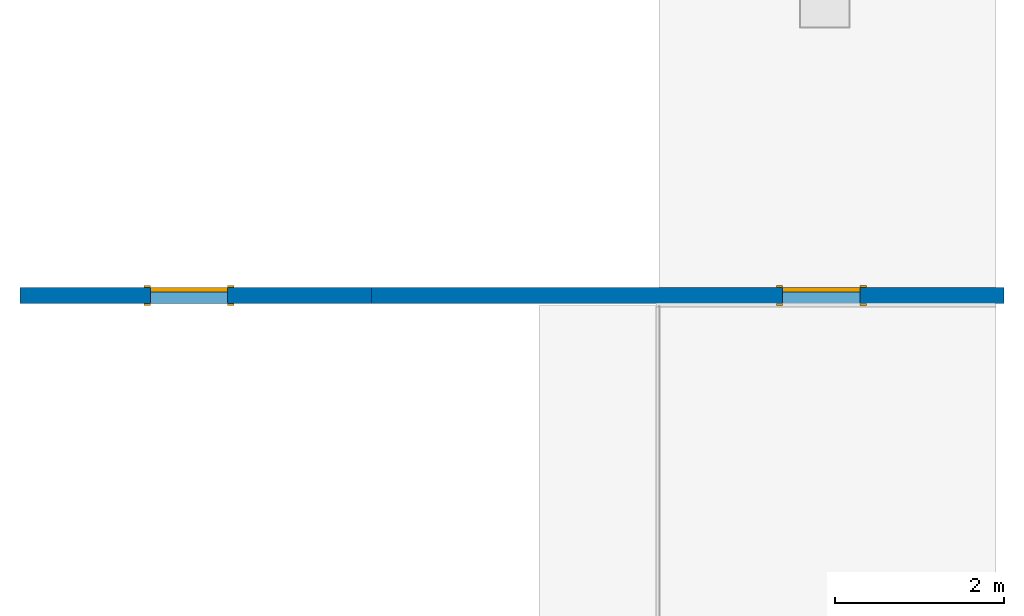
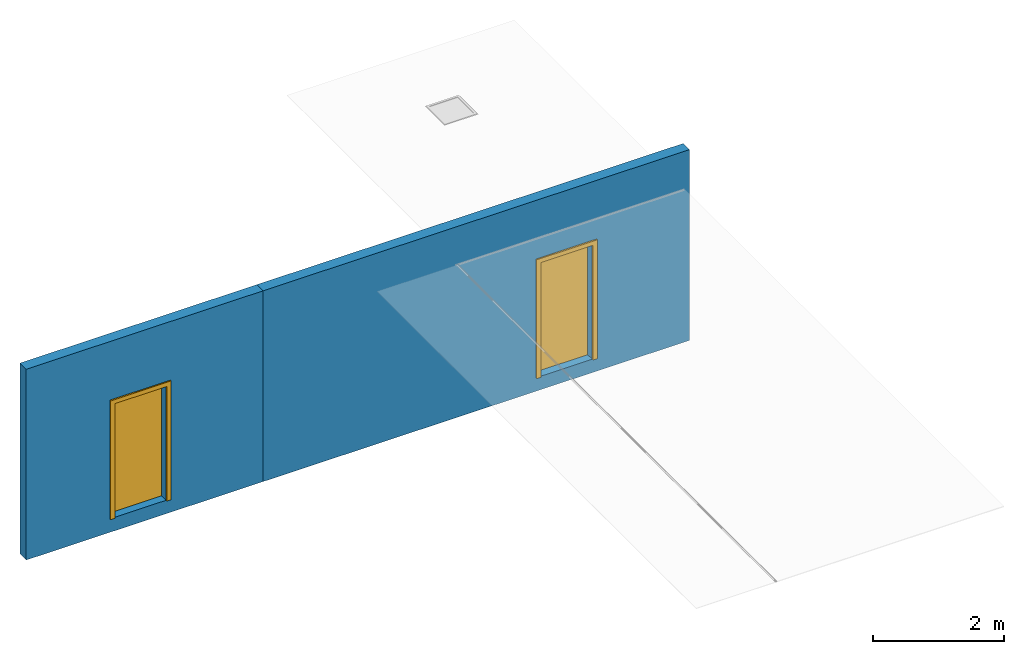
# One storey, part 1 of 4: 2 doors, 2 walls, 2 openings.
"""IFC2X3 building model written with IfcOpenShell, lengths in millimetres."""

from ifc_helpers import new_model, entity, si_unit, converted_unit, derived_unit, direction, frame, frame_2d, origin, place, context, subcontext, project, spatial, polyline, rectangle, outline, extrude, source, transform, mapped, material, material_list, layer, layer_set, layer_usage, type_object, type_shapes, element, fill, save


model = new_model("IFC2X3")

# Units and contexts
model_context = context("Model", 3, precision=0.01, world=origin(), true_north=direction((6.12303176911189e-17, 1.0)))
body_context = subcontext(model_context, "Body", "Model", "MODEL_VIEW")
ifc_project = project(units=[si_unit("LENGTHUNIT", "METRE", prefix="MILLI"), si_unit("AREAUNIT", "SQUARE_METRE"), si_unit("VOLUMEUNIT", "CUBIC_METRE"), converted_unit("PLANEANGLEUNIT", "DEGREE", entity("IfcRatioMeasure", 0.0174532925199433), si_unit("PLANEANGLEUNIT", "RADIAN"), dimensions=[0, 0, 0, 0, 0, 0, 0]), si_unit("MASSUNIT", "GRAM", prefix="KILO"), derived_unit("MASSDENSITYUNIT", [(si_unit("MASSUNIT", "GRAM", prefix="KILO"), 1), (si_unit("LENGTHUNIT", "METRE"), -3)]), si_unit("TIMEUNIT", "SECOND"), si_unit("FREQUENCYUNIT", "HERTZ"), si_unit("THERMODYNAMICTEMPERATUREUNIT", "DEGREE_CELSIUS"), derived_unit("THERMALTRANSMITTANCEUNIT", [(si_unit("MASSUNIT", "GRAM", prefix="KILO"), 1), (si_unit("THERMODYNAMICTEMPERATUREUNIT", "KELVIN"), -1), (si_unit("TIMEUNIT", "SECOND"), -3)]), derived_unit("VOLUMETRICFLOWRATEUNIT", [(si_unit("LENGTHUNIT", "METRE"), 3), (si_unit("TIMEUNIT", "SECOND"), -1)]), si_unit("ELECTRICCURRENTUNIT", "AMPERE"), si_unit("ELECTRICVOLTAGEUNIT", "VOLT"), si_unit("POWERUNIT", "WATT"), si_unit("FORCEUNIT", "NEWTON", prefix="KILO"), si_unit("ILLUMINANCEUNIT", "LUX"), si_unit("LUMINOUSFLUXUNIT", "LUMEN"), si_unit("LUMINOUSINTENSITYUNIT", "CANDELA"), derived_unit("USERDEFINED", [(si_unit("MASSUNIT", "GRAM", prefix="KILO"), -1), (si_unit("LENGTHUNIT", "METRE"), -2), (si_unit("TIMEUNIT", "SECOND"), 3), (si_unit("LUMINOUSFLUXUNIT", "LUMEN"), 1)]), derived_unit("LINEARVELOCITYUNIT", [(si_unit("LENGTHUNIT", "METRE"), 1), (si_unit("TIMEUNIT", "SECOND"), -1)]), si_unit("PRESSUREUNIT", "PASCAL"), derived_unit("USERDEFINED", [(si_unit("LENGTHUNIT", "METRE"), -2), (si_unit("MASSUNIT", "GRAM", prefix="KILO"), 1), (si_unit("TIMEUNIT", "SECOND"), -2)])], contexts=[model_context])

# Site, building, storey
site_placement = place(None, origin())
site = spatial("IfcSite", under=ifc_project, at=site_placement, CompositionType="ELEMENT")
building_placement = place(site_placement, origin())
building = spatial("IfcBuilding", under=site, at=building_placement, CompositionType="ELEMENT")
storey_placement = place(building_placement, origin())
storey = spatial("IfcBuildingStorey", under=building, at=storey_placement, Name="Base Level", CompositionType="ELEMENT", Elevation=0.0)

# Wall, opening, door
ifc_material_1 = material(Name="np_Plastered")
ifc_layer = layer(ifc_material_1, 190.0)
ifc_layer_set = layer_set([ifc_layer], Name="Basic Wall:190mm BLOCK- plastered")
ifc_layer_usage_1 = layer_usage(ifc_layer_set, "AXIS2", "NEGATIVE", 95.0)
wall_type = type_object("IfcWallType", Name="Basic Wall:190mm BLOCK- plastered", PredefinedType="STANDARD", material=ifc_layer_set)
wall_1_placement = place(building_placement, frame((195391.200975521, 42312.9193803935, -250.0)))
wall_1 = element("IfcWallStandardCase", 1, at=wall_1_placement, inside=storey, type_object=wall_type, material=ifc_layer_usage_1, Name="Basic Wall:190mm BLOCK- plastered:2480", ObjectType="Basic Wall:190mm BLOCK- plastered", context=body_context, shape_type="SweptSolid", body=[
    extrude(rectangle(XDim=4170.5335774123, YDim=189.999999999991, at=frame_2d((2085.26678870615, 2.72848410531878e-12), x_axis=(-1.0, 0.0))), origin(), (0.0, 0.0, 1.0), 3550.00000000014),
])
opening_1_placement = place(wall_1_placement, frame((1546.0335774124, -95.0, 250.0)))
opening_1 = element("IfcOpeningElement", 2, at=opening_1_placement, cuts=wall_1, Name="M_Single-Flush:0915 x 2134mm:2481:1", ObjectType="Opening", context=body_context, shape_type="SweptSolid", body=[
    extrude(rectangle(XDim=915.0, YDim=2134.0, at=frame_2d((1067.0, 457.499999999991), x_axis=(0.0, 1.0))), frame((0.0, 0.0, 0.0), z_axis=(0.0, 1.0, 0.0), x_axis=(0.0, 0.0, 1.0)), (0.0, 0.0, 1.0), 190.0),
])
ifc_material_2 = material(Name="Door - Frame")
ifc_material_3 = material(Name="Door - Panel")
ifc_material_list_1 = material_list([ifc_material_2, ifc_material_3])
ifc_material_list_2 = material_list([ifc_material_2, ifc_material_3])
door_style = type_object("IfcDoorStyle", Name="0915 x 2134mm", ConstructionType="NOTDEFINED", OperationType="SINGLE_SWING_RIGHT", ParameterTakesPrecedence=False, Sizeable=False, material=ifc_material_list_2)
shared_shape = source(origin(), body_context, "Body", "SweptSolid", [
    extrude(outline(polyline([(-533.5, -1124.0), (533.5, -1124.0), (533.5, 1086.0), (457.5, 1086.0), (457.5, -1048.0), (-457.5, -1048.0), (-457.5, 1086.0), (-533.5, 1086.0), (-533.5, -1124.0)])), frame((457.500000000001, 190.0, 1086.0), z_axis=(0.0, 1.0, 0.0), x_axis=(1.0, 0.0, 0.0)), (0.0, 0.0, 1.0), 24.9999999999945),
    extrude(outline(polyline([(-1124.0, -533.499999999997), (1086.0, -533.499999999997), (1086.0, -457.500000000007), (-1048.0, -457.500000000007), (-1048.0, 457.500000000002), (1086.0, 457.500000000002), (1086.0, 533.500000000003), (-1124.0, 533.500000000003), (-1124.0, -533.499999999997)])), frame((457.500000000003, -25.0, 1086.0), z_axis=(0.0, 1.0, 0.0), x_axis=(0.0, 0.0, -1.0)), (0.0, 0.0, 1.0), 25.0000000000056),
    extrude(rectangle(XDim=51.0, YDim=915.0, at=frame_2d((5.32907051820075e-15, 0.0), x_axis=(1.0, 0.0))), frame((457.5, 164.499999999999, 0.0), z_axis=(0.0, 0.0, 1.0), x_axis=(0.0, 1.0, 0.0)), (0.0, 0.0, 1.0), 2134.0),
])
type_shapes(door_style, [shared_shape])
door_1_placement = place(opening_1_placement, origin())
door_1 = element("IfcDoor", 3, at=door_1_placement, inside=storey, type_object=door_style, material=ifc_material_list_1, Name="M_Single-Flush:0915 x 2134mm:2481", ObjectType="M_Single-Flush:0915 x 2134mm", OverallHeight=2134.0, OverallWidth=915.000000000017, context=body_context, shape_type="MappedRepresentation", body=[
    mapped(shared_shape, transform((0.0, 0.0, 0.0), scale=1.0)),
])
fill(opening_1, door_1)

ifc_layer_usage_2 = layer_usage(ifc_layer_set, "AXIS2", "NEGATIVE", 95.0)
wall_2_placement = place(building_placement, frame((199561.734552934, 42312.9193803935, -250.0)))
wall_2 = element("IfcWallStandardCase", 4, at=wall_2_placement, inside=storey, type_object=wall_type, material=ifc_layer_usage_2, Name="Basic Wall:190mm BLOCK- plastered:2489", ObjectType="Basic Wall:190mm BLOCK- plastered", context=body_context, shape_type="SweptSolid", body=[
    extrude(rectangle(XDim=7500.00000000003, YDim=189.999999999991, at=frame_2d((3750.00000000001, 5.6843418860808e-13), x_axis=(-1.0, 0.0))), origin(), (0.0, 0.0, 1.0), 3550.00000000014),
])
opening_2_placement = place(wall_2_placement, frame((4875.50000000016, -95.0, 250.0)))
opening_2 = element("IfcOpeningElement", 5, at=opening_2_placement, cuts=wall_2, Name="M_Single-Flush:0915 x 2134mm:2490:1", ObjectType="Opening", context=body_context, shape_type="SweptSolid", body=[
    extrude(rectangle(XDim=915.0, YDim=2134.0, at=frame_2d((1067.0, 457.499999999991), x_axis=(0.0, 1.0))), frame((0.0, 0.0, 0.0), z_axis=(0.0, 1.0, 0.0), x_axis=(0.0, 0.0, 1.0)), (0.0, 0.0, 1.0), 190.0),
])
ifc_material_list_3 = material_list([ifc_material_2, ifc_material_3])
door_2_placement = place(opening_2_placement, origin())
door_2 = element("IfcDoor", 6, at=door_2_placement, inside=storey, type_object=door_style, material=ifc_material_list_3, Name="M_Single-Flush:0915 x 2134mm:2490", ObjectType="M_Single-Flush:0915 x 2134mm", OverallHeight=2134.0, OverallWidth=915.000000000017, context=body_context, shape_type="MappedRepresentation", body=[
    mapped(shared_shape, transform((0.0, 0.0, 0.0), scale=1.0)),
])
fill(opening_2, door_2)

save(model, "model.ifc")
